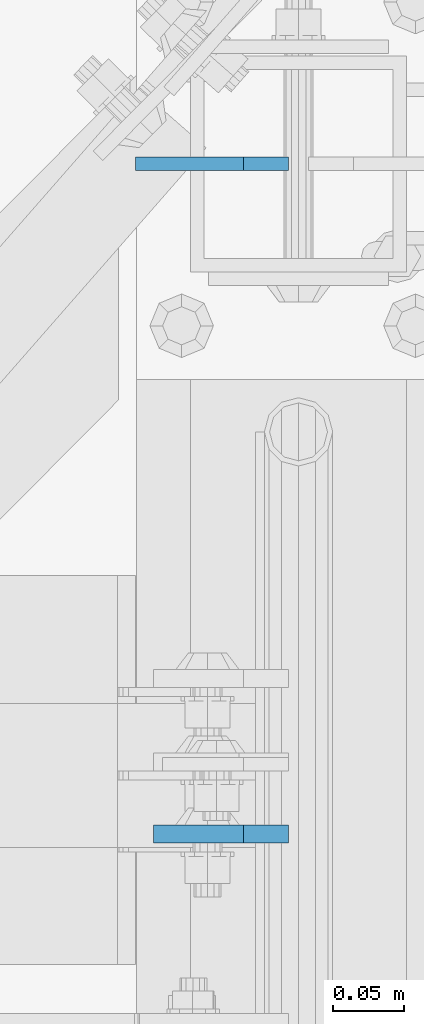
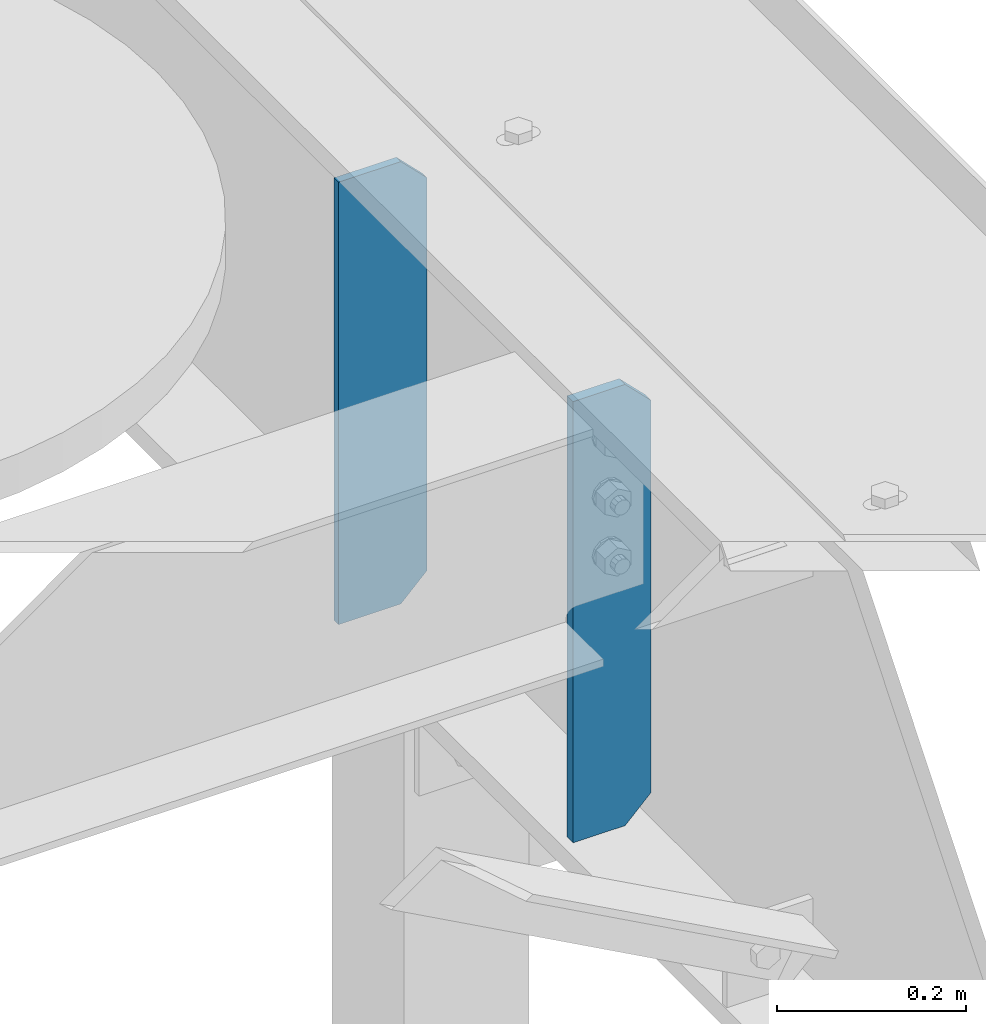
# One storey, part 1649 of 1876: 2 plates, 1 element without a shape of its own.
"""IFC2X3 building model written with IfcOpenShell, lengths in millimetres."""

from ifc_helpers import new_model, si_unit, frame, origin_with_axes, place, context, subcontext, project, spatial, faceted_brep, material, type_object, element, aggregate, save


model = new_model("IFC2X3")

# Units and contexts
model_context = context("Model", 3, precision=1e-05, world=origin_with_axes())
body_context = subcontext(model_context, "Body", "Model", "MODEL_VIEW")
ifc_project = project(units=[si_unit("LENGTHUNIT", "METRE", prefix="MILLI"), si_unit("AREAUNIT", "SQUARE_METRE"), si_unit("VOLUMEUNIT", "CUBIC_METRE"), si_unit("MASSUNIT", "GRAM", prefix="KILO"), si_unit("TIMEUNIT", "SECOND"), si_unit("PLANEANGLEUNIT", "RADIAN"), si_unit("SOLIDANGLEUNIT", "STERADIAN"), si_unit("THERMODYNAMICTEMPERATUREUNIT", "DEGREE_CELSIUS"), si_unit("LUMINOUSINTENSITYUNIT", "LUMEN")], contexts=[model_context])

# Site, building, storey
site_placement = place(None, origin_with_axes())
site = spatial("IfcSite", under=ifc_project, at=site_placement, CompositionType="ELEMENT")
building_placement = place(site_placement, origin_with_axes())
building = spatial("IfcBuilding", under=site, at=building_placement, Name="Undefined", CompositionType="ELEMENT")
storey_placement = place(building_placement, origin_with_axes())
storey = spatial("IfcBuildingStorey", under=building, at=storey_placement, Name="Undefined", CompositionType="ELEMENT", Elevation=0.0)

# Assembly, plates
assembly_placement = place(storey_placement, origin_with_axes())
assembly = element("IfcElementAssembly", 1, at=assembly_placement, inside=storey, Name="BEAM", AssemblyPlace="NOTDEFINED", PredefinedType="RIGID_FRAME")
ifc_material = material(Name="STEEL/A36")
plate_type_1 = type_object("IfcPlateType", PredefinedType="NOTDEFINED")
plate_1_placement = place(assembly_placement, frame((7612.85625, 3082.92420053482, 21959.8875), z_axis=(0.0, 0.0, 1.0), x_axis=(-1.0, 0.0, 0.0)))
plate_1 = element("IfcPlate", 2, at=plate_1_placement, type_object=plate_type_1, material=ifc_material, Name="PLATE", context=body_context, shape_type="Brep", body=[
    faceted_brep([(0.0, -6.34999999999991, 31.75), (0.0, -6.35000000000036, 538.162475585938), (0.0, 6.35000000000036, 538.162475585938), (0.0, 6.34999999999991, 31.75), (31.75, -6.35000000000036, 569.912475585938), (31.75, 6.35000000000036, 569.912475585938), (95.25, -6.35000000000036, 569.912475585938), (95.25, 6.35000000000036, 569.912475585938), (95.25, -6.35000000000036, 0.0), (95.25, 6.35000000000036, 0.0), (31.75, -6.34999999999991, 0.0), (31.75, 6.34999999999991, 0.0)], [[[0, 1, 2, 3]], [[1, 4, 5, 2]], [[4, 6, 7, 5]], [[6, 8, 9, 7]], [[8, 10, 11, 9]], [[10, 0, 3, 11]], [[5, 7, 9, 11, 3, 2]], [[10, 8, 6, 4, 1, 0]]]),
])
plate_type_2 = type_object("IfcPlateType", PredefinedType="NOTDEFINED")
plate_2_placement = place(assembly_placement, frame((7612.85625, 3556.0, 21958.3), z_axis=(0.0, 0.0, 1.0), x_axis=(-1.0, 0.0, 0.0)))
plate_2 = element("IfcPlate", 3, at=plate_2_placement, type_object=plate_type_2, material=ifc_material, Name="PLATE", context=body_context, shape_type="Brep", body=[
    faceted_brep([(-9.76996261670138e-14, -4.76250000000073, 31.75), (0.0, -4.76249999999982, 539.75), (0.0, 4.76249999999982, 539.75), (-9.76996261670138e-14, 4.76250000000073, 31.75), (31.75, -4.76249999999982, 571.5), (31.75, 4.76249999999982, 571.5), (107.949996948242, -4.76249999999982, 571.5), (107.949996948242, 4.76249999999982, 571.5), (107.950006484985, -4.76250000000073, 0.0), (107.950006484985, 4.76250000000073, 0.0), (31.75, -4.76250000000073, 0.0), (31.75, 4.76250000000073, 0.0)], [[[0, 1, 2, 3]], [[1, 4, 5, 2]], [[4, 6, 7, 5]], [[6, 8, 9, 7]], [[8, 10, 11, 9]], [[10, 0, 3, 11]], [[5, 7, 9, 11, 3, 2]], [[10, 8, 6, 4, 1, 0]]]),
])
aggregate(assembly, [plate_2, plate_1])

save(model, "model.ifc")
